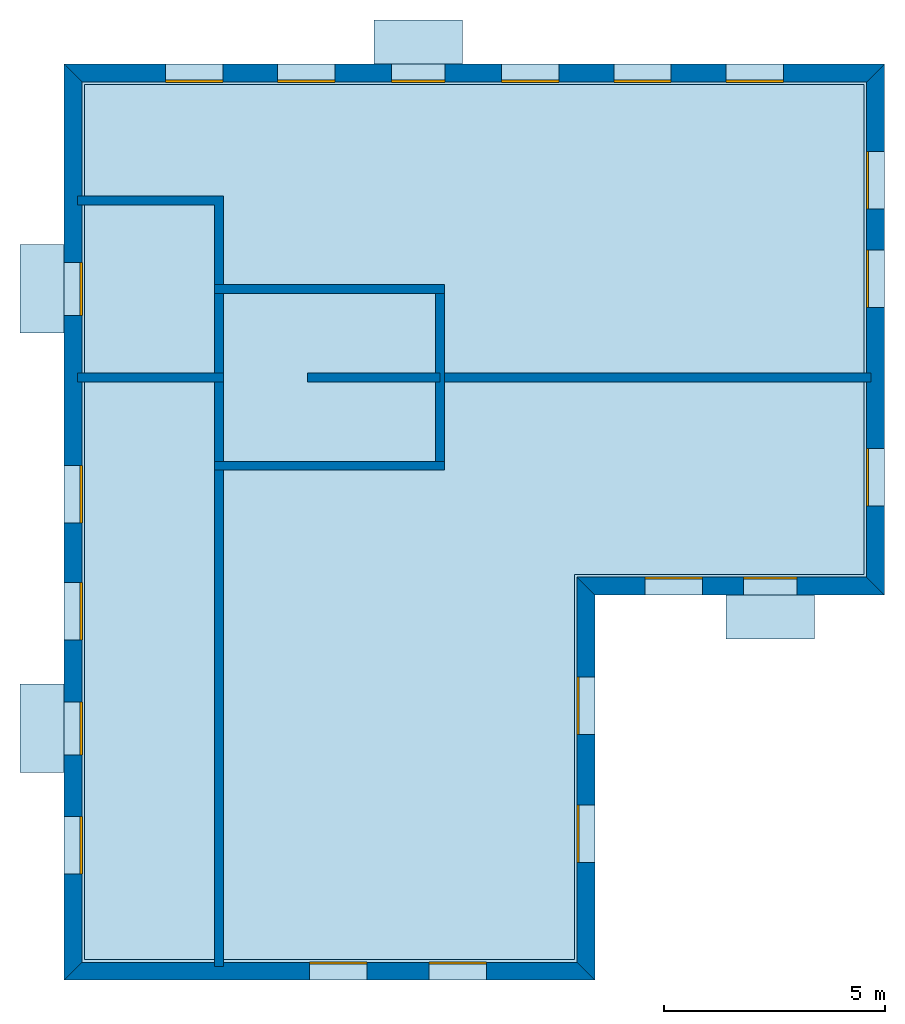
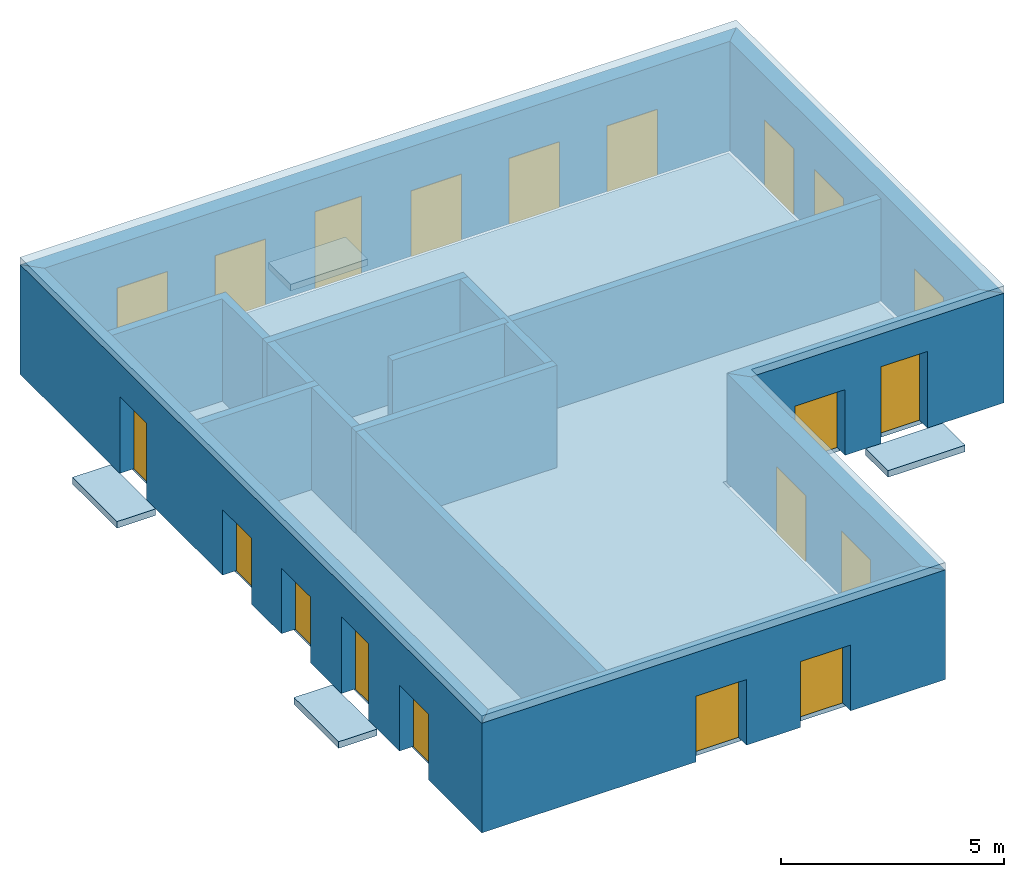
# One storey: 20 windows, 15 walls, 6 slabs, 20 openings.
"""IFC4 building model written with IfcOpenShell, lengths in metres."""

from ifc_helpers import new_model, si_unit, frame, origin_with_axes, place, context, subcontext, project, spatial, polyline, line, indexed_curve, outline, extrude, element, fill, save


model = new_model("IFC4")

# Units and contexts
model_context = context("Model", 3, precision=1e-05, world=origin_with_axes())
body_context = subcontext(model_context, "Body", "Model", "MODEL_VIEW")
ifc_project = project(units=[si_unit("AREAUNIT", "SQUARE_METRE"), si_unit("VOLUMEUNIT", "CUBIC_METRE"), si_unit("LENGTHUNIT", "METRE")], contexts=[model_context])

# Site, building, storey
site = spatial("IfcSite", under=ifc_project)
building = spatial("IfcBuilding", under=site, Name="Building 1")
storey_placement = place(None, frame((0.0, 0.0, 7.0), z_axis=(0.0, 0.0, 1.0), x_axis=(1.0, 0.0, 0.0)))
storey = spatial("IfcBuildingStorey", under=building, at=storey_placement, Name="03 Storey")

# Slabs
slab_1_placement = place(storey_placement, origin_with_axes())
element("IfcSlab", 1, at=slab_1_placement, inside=storey, Name="Slab", context=body_context, shape_type="SweptSolid", body=[
    extrude(outline(indexed_curve([(15.533354, 14.715575), (22.079464, 14.715575), (22.079464, 25.795575), (4.453354, 25.795575), (4.453354, 6.0082), (15.533354, 6.0082)], segments=[line(1, 2), line(2, 3), line(3, 4), line(4, 5), line(5, 6)])), origin_with_axes(), (0.0, 0.0, -1.0), 0.2),
])
slab_2_placement = place(storey_placement, origin_with_axes())
element("IfcSlab", 2, at=slab_2_placement, inside=storey, Name="Balcony", context=body_context, shape_type="SweptSolid", body=[
    extrude(outline(indexed_curve([(20.9574273333333, 14.255575), (20.9574273333333, 13.255575), (18.9574273333333, 13.255575), (18.9574273333333, 14.255575)], segments=[line(1, 2), line(2, 3), line(3, 4)])), origin_with_axes(), (0.0, 0.0, -1.0), 0.18),
])
slab_3_placement = place(storey_placement, origin_with_axes())
element("IfcSlab", 3, at=slab_3_placement, inside=storey, Name="Balcony", context=body_context, shape_type="SweptSolid", body=[
    extrude(outline(indexed_curve([(10.9988297142857, 26.255575), (10.9988297142857, 27.255575), (12.9988297142857, 27.255575), (12.9988297142857, 26.255575)], segments=[line(1, 2), line(2, 3), line(3, 4)])), origin_with_axes(), (0.0, 0.0, -1.0), 0.18),
])
slab_4_placement = place(storey_placement, origin_with_axes())
element("IfcSlab", 4, at=slab_4_placement, inside=storey, Name="Balcony", context=body_context, shape_type="SweptSolid", body=[
    extrude(outline(indexed_curve([(3.993354, 10.2388972), (2.993354, 10.2388972), (2.993354, 12.2388972), (3.993354, 12.2388972)], segments=[line(1, 2), line(2, 3), line(3, 4)])), origin_with_axes(), (0.0, 0.0, -1.0), 0.18),
])
slab_5_placement = place(storey_placement, origin_with_axes())
element("IfcSlab", 5, at=slab_5_placement, inside=storey, Name="Balcony", context=body_context, shape_type="SweptSolid", body=[
    extrude(outline(indexed_curve([(3.993354, 20.174943), (2.993354, 20.174943), (2.993354, 22.174943), (3.993354, 22.174943)], segments=[line(1, 2), line(2, 3), line(3, 4)])), origin_with_axes(), (0.0, 0.0, -1.0), 0.18),
])
slab_6_placement = place(storey_placement, frame((15.993353843689, 14.2555751800537, 0.0), z_axis=(0.0, 0.0, 1.0), x_axis=(1.0, 0.0, 0.0)))
element("IfcSlab", 6, at=slab_6_placement, inside=storey, Name="Slab", context=body_context, shape_type="SweptSolid", body=[
    extrude(outline(polyline([(0.0, 0.0), (6.54611, 0.0), (6.54611, 12.0), (-12.0, 12.0), (-12.0, -8.707375), (0.0, -8.707375), (0.0, 0.0)])), frame((0.0, 0.0, 3.0), z_axis=(0.0, 0.0, 1.0), x_axis=(1.0, 0.0, 0.0)), (0.0, 7.54979012640433e-08, 1.0), 0.2),
])

# Walls
wall_1_placement = place(storey_placement, origin_with_axes())
element("IfcWall", 7, at=wall_1_placement, inside=storey, Name="Wall", context=body_context, shape_type="SweptSolid", body=[
    extrude(outline(indexed_curve([(22.239464, 19.274943), (12.393354, 19.274943), (12.393354, 19.074943), (22.239464, 19.074943)], segments=[line(1, 2), line(2, 3), line(3, 4)])), origin_with_axes(), (0.0, 0.0, 1.0), 2.8),
])
wall_2_placement = place(storey_placement, origin_with_axes())
element("IfcWall", 8, at=wall_2_placement, inside=storey, Name="Wall", context=body_context, shape_type="SweptSolid", body=[
    extrude(outline(indexed_curve([(7.593354, 17.274943), (7.393354, 17.274943), (7.393354, 5.8482), (7.593354, 5.8482)], segments=[line(1, 2), line(2, 3), line(3, 4)])), origin_with_axes(), (0.0, 0.0, 1.0), 2.8),
])
wall_3_placement = place(storey_placement, origin_with_axes())
element("IfcWall", 9, at=wall_3_placement, inside=storey, Name="Wall", context=body_context, shape_type="SweptSolid", body=[
    extrude(outline(indexed_curve([(7.593354, 19.274943), (4.293354, 19.274943), (4.293354, 19.074943), (7.593354, 19.074943)], segments=[line(1, 2), line(2, 3), line(3, 4)])), origin_with_axes(), (0.0, 0.0, 1.0), 2.8),
])
wall_4_placement = place(storey_placement, origin_with_axes())
element("IfcWall", 10, at=wall_4_placement, inside=storey, Name="Wall", context=body_context, shape_type="SweptSolid", body=[
    extrude(outline(indexed_curve([(7.593354, 23.274943), (4.293354, 23.274943), (4.293354, 23.074943), (7.393354, 23.074943), (7.393354, 21.074943), (7.593354, 21.074943)], segments=[line(1, 2), line(2, 3), line(3, 4), line(4, 5), line(5, 6)])), origin_with_axes(), (0.0, 0.0, 1.0), 2.8),
])

# Wall, openings, windows
wall_5_placement = place(storey_placement, origin_with_axes())
wall_5 = element("IfcWall", 11, at=wall_5_placement, inside=storey, Name="Facade", context=body_context, shape_type="SweptSolid", body=[
    extrude(outline(indexed_curve([(15.593354, 14.655575), (22.139464, 14.655575), (22.539464, 14.255575), (15.993354, 14.255575)], segments=[line(1, 2), line(2, 3), line(3, 4)])), origin_with_axes(), (0.0, 0.0, 1.0), 3.0),
])
opening_1_placement = place(wall_5_placement, origin_with_axes())
opening_1 = element("IfcOpeningElement", 12, at=opening_1_placement, cuts=wall_5, Name="Opening", context=body_context, shape_type="SweptSolid", body=[
    extrude(outline(indexed_curve([(17.1253906666667, 14.215575), (17.1253906666667, 14.715575), (18.4253906666667, 14.715575), (18.4253906666667, 14.215575)], segments=[line(1, 2), line(2, 3), line(3, 4)])), origin_with_axes(), (0.0, 0.0, 1.0), 1.8),
])
opening_2_placement = place(wall_5_placement, origin_with_axes())
opening_2 = element("IfcOpeningElement", 13, at=opening_2_placement, cuts=wall_5, Name="Opening", context=body_context, shape_type="SweptSolid", body=[
    extrude(outline(indexed_curve([(19.3574273333333, 14.215575), (19.3574273333333, 14.715575), (20.5574273333333, 14.715575), (20.5574273333333, 14.215575)], segments=[line(1, 2), line(2, 3), line(3, 4)])), origin_with_axes(), (0.0, 0.0, 1.0), 2.1),
])
window_1_placement = place(storey_placement, origin_with_axes())
window_1 = element("IfcWindow", 14, at=window_1_placement, inside=storey, Name="Window", PredefinedType="WINDOW", context=body_context, shape_type="SweptSolid", body=[
    extrude(outline(indexed_curve([(17.1253906666667, 14.615575), (17.1253906666667, 14.665575), (18.4253906666667, 14.665575), (18.4253906666667, 14.615575)], segments=[line(1, 2), line(2, 3), line(3, 4)])), origin_with_axes(), (0.0, 0.0, 1.0), 1.8),
])
fill(opening_1, window_1)
window_2_placement = place(storey_placement, origin_with_axes())
window_2 = element("IfcWindow", 15, at=window_2_placement, inside=storey, Name="Window", PredefinedType="WINDOW", context=body_context, shape_type="SweptSolid", body=[
    extrude(outline(indexed_curve([(19.3574273333333, 14.615575), (19.3574273333333, 14.665575), (20.5574273333333, 14.665575), (20.5574273333333, 14.615575)], segments=[line(1, 2), line(2, 3), line(3, 4)])), origin_with_axes(), (0.0, 0.0, 1.0), 2.1),
])
fill(opening_2, window_2)

wall_6_placement = place(storey_placement, origin_with_axes())
wall_6 = element("IfcWall", 16, at=wall_6_placement, inside=storey, Name="Facade", context=body_context, shape_type="SweptSolid", body=[
    extrude(outline(indexed_curve([(22.139464, 14.655575), (22.139464, 25.855575), (22.539464, 26.255575), (22.539464, 14.255575)], segments=[line(1, 2), line(2, 3), line(3, 4)])), origin_with_axes(), (0.0, 0.0, 1.0), 3.0),
])
opening_3_placement = place(wall_6_placement, origin_with_axes())
opening_3 = element("IfcOpeningElement", 17, at=opening_3_placement, cuts=wall_6, Name="Opening", context=body_context, shape_type="SweptSolid", body=[
    extrude(outline(indexed_curve([(22.579464, 16.265259), (22.079464, 16.265259), (22.079464, 17.565259), (22.579464, 17.565259)], segments=[line(1, 2), line(2, 3), line(3, 4)])), origin_with_axes(), (0.0, 0.0, 1.0), 1.8),
])
opening_4_placement = place(wall_6_placement, origin_with_axes())
opening_4 = element("IfcOpeningElement", 18, at=opening_4_placement, cuts=wall_6, Name="Opening", context=body_context, shape_type="SweptSolid", body=[
    extrude(outline(indexed_curve([(22.579464, 20.7518203333333), (22.079464, 20.7518203333333), (22.079464, 22.0518203333333), (22.579464, 22.0518203333333)], segments=[line(1, 2), line(2, 3), line(3, 4)])), origin_with_axes(), (0.0, 0.0, 1.0), 1.8),
])
opening_5_placement = place(wall_6_placement, origin_with_axes())
opening_5 = element("IfcOpeningElement", 19, at=opening_5_placement, cuts=wall_6, Name="Opening", context=body_context, shape_type="SweptSolid", body=[
    extrude(outline(indexed_curve([(22.579464, 22.9786976666667), (22.079464, 22.9786976666667), (22.079464, 24.2786976666667), (22.579464, 24.2786976666667)], segments=[line(1, 2), line(2, 3), line(3, 4)])), origin_with_axes(), (0.0, 0.0, 1.0), 1.8),
])
window_3_placement = place(storey_placement, origin_with_axes())
window_3 = element("IfcWindow", 20, at=window_3_placement, inside=storey, Name="Window", PredefinedType="WINDOW", context=body_context, shape_type="SweptSolid", body=[
    extrude(outline(indexed_curve([(22.179464, 16.265259), (22.129464, 16.265259), (22.129464, 17.565259), (22.179464, 17.565259)], segments=[line(1, 2), line(2, 3), line(3, 4)])), origin_with_axes(), (0.0, 0.0, 1.0), 1.8),
])
fill(opening_3, window_3)
window_4_placement = place(storey_placement, origin_with_axes())
window_4 = element("IfcWindow", 21, at=window_4_placement, inside=storey, Name="Window", PredefinedType="WINDOW", context=body_context, shape_type="SweptSolid", body=[
    extrude(outline(indexed_curve([(22.179464, 20.7518203333333), (22.129464, 20.7518203333333), (22.129464, 22.0518203333333), (22.179464, 22.0518203333333)], segments=[line(1, 2), line(2, 3), line(3, 4)])), origin_with_axes(), (0.0, 0.0, 1.0), 1.8),
])
fill(opening_4, window_4)
window_5_placement = place(storey_placement, origin_with_axes())
window_5 = element("IfcWindow", 22, at=window_5_placement, inside=storey, Name="Window", PredefinedType="WINDOW", context=body_context, shape_type="SweptSolid", body=[
    extrude(outline(indexed_curve([(22.179464, 22.9786976666667), (22.129464, 22.9786976666667), (22.129464, 24.2786976666667), (22.179464, 24.2786976666667)], segments=[line(1, 2), line(2, 3), line(3, 4)])), origin_with_axes(), (0.0, 0.0, 1.0), 1.8),
])
fill(opening_5, window_5)

wall_7_placement = place(storey_placement, origin_with_axes())
wall_7 = element("IfcWall", 23, at=wall_7_placement, inside=storey, Name="Facade", context=body_context, shape_type="SweptSolid", body=[
    extrude(outline(indexed_curve([(22.139464, 25.855575), (4.393354, 25.855575), (3.993354, 26.255575), (22.539464, 26.255575)], segments=[line(1, 2), line(2, 3), line(3, 4)])), origin_with_axes(), (0.0, 0.0, 1.0), 3.0),
])
opening_6_placement = place(wall_7_placement, origin_with_axes())
opening_6 = element("IfcOpeningElement", 24, at=opening_6_placement, cuts=wall_7, Name="Opening", context=body_context, shape_type="SweptSolid", body=[
    extrude(outline(indexed_curve([(20.2543054285714, 26.295575), (20.2543054285714, 25.795575), (18.9543054285714, 25.795575), (18.9543054285714, 26.295575)], segments=[line(1, 2), line(2, 3), line(3, 4)])), origin_with_axes(), (0.0, 0.0, 1.0), 1.8),
])
opening_7_placement = place(wall_7_placement, origin_with_axes())
opening_7 = element("IfcOpeningElement", 25, at=opening_7_placement, cuts=wall_7, Name="Opening", context=body_context, shape_type="SweptSolid", body=[
    extrude(outline(indexed_curve([(17.7191468571429, 26.295575), (17.7191468571429, 25.795575), (16.4191468571429, 25.795575), (16.4191468571429, 26.295575)], segments=[line(1, 2), line(2, 3), line(3, 4)])), origin_with_axes(), (0.0, 0.0, 1.0), 1.8),
])
opening_8_placement = place(wall_7_placement, origin_with_axes())
opening_8 = element("IfcOpeningElement", 26, at=opening_8_placement, cuts=wall_7, Name="Opening", context=body_context, shape_type="SweptSolid", body=[
    extrude(outline(indexed_curve([(15.1839882857143, 26.295575), (15.1839882857143, 25.795575), (13.8839882857143, 25.795575), (13.8839882857143, 26.295575)], segments=[line(1, 2), line(2, 3), line(3, 4)])), origin_with_axes(), (0.0, 0.0, 1.0), 1.8),
])
opening_9_placement = place(wall_7_placement, origin_with_axes())
opening_9 = element("IfcOpeningElement", 27, at=opening_9_placement, cuts=wall_7, Name="Opening", context=body_context, shape_type="SweptSolid", body=[
    extrude(outline(indexed_curve([(12.5988297142857, 26.295575), (12.5988297142857, 25.795575), (11.3988297142857, 25.795575), (11.3988297142857, 26.295575)], segments=[line(1, 2), line(2, 3), line(3, 4)])), origin_with_axes(), (0.0, 0.0, 1.0), 2.1),
])
opening_10_placement = place(wall_7_placement, origin_with_axes())
opening_10 = element("IfcOpeningElement", 28, at=opening_10_placement, cuts=wall_7, Name="Opening", context=body_context, shape_type="SweptSolid", body=[
    extrude(outline(indexed_curve([(10.1136711428571, 26.295575), (10.1136711428571, 25.795575), (8.81367114285714, 25.795575), (8.81367114285714, 26.295575)], segments=[line(1, 2), line(2, 3), line(3, 4)])), origin_with_axes(), (0.0, 0.0, 1.0), 1.8),
])
opening_11_placement = place(wall_7_placement, origin_with_axes())
opening_11 = element("IfcOpeningElement", 29, at=opening_11_placement, cuts=wall_7, Name="Opening", context=body_context, shape_type="SweptSolid", body=[
    extrude(outline(indexed_curve([(7.57851257142857, 26.295575), (7.57851257142857, 25.795575), (6.27851257142857, 25.795575), (6.27851257142857, 26.295575)], segments=[line(1, 2), line(2, 3), line(3, 4)])), origin_with_axes(), (0.0, 0.0, 1.0), 1.8),
])
window_6_placement = place(storey_placement, origin_with_axes())
window_6 = element("IfcWindow", 30, at=window_6_placement, inside=storey, Name="Window", PredefinedType="WINDOW", context=body_context, shape_type="SweptSolid", body=[
    extrude(outline(indexed_curve([(20.2543054285714, 25.895575), (20.2543054285714, 25.845575), (18.9543054285714, 25.845575), (18.9543054285714, 25.895575)], segments=[line(1, 2), line(2, 3), line(3, 4)])), origin_with_axes(), (0.0, 0.0, 1.0), 1.8),
])
fill(opening_6, window_6)
window_7_placement = place(storey_placement, origin_with_axes())
window_7 = element("IfcWindow", 31, at=window_7_placement, inside=storey, Name="Window", PredefinedType="WINDOW", context=body_context, shape_type="SweptSolid", body=[
    extrude(outline(indexed_curve([(17.7191468571429, 25.895575), (17.7191468571429, 25.845575), (16.4191468571429, 25.845575), (16.4191468571429, 25.895575)], segments=[line(1, 2), line(2, 3), line(3, 4)])), origin_with_axes(), (0.0, 0.0, 1.0), 1.8),
])
fill(opening_7, window_7)
window_8_placement = place(storey_placement, origin_with_axes())
window_8 = element("IfcWindow", 32, at=window_8_placement, inside=storey, Name="Window", PredefinedType="WINDOW", context=body_context, shape_type="SweptSolid", body=[
    extrude(outline(indexed_curve([(15.1839882857143, 25.895575), (15.1839882857143, 25.845575), (13.8839882857143, 25.845575), (13.8839882857143, 25.895575)], segments=[line(1, 2), line(2, 3), line(3, 4)])), origin_with_axes(), (0.0, 0.0, 1.0), 1.8),
])
fill(opening_8, window_8)
window_9_placement = place(storey_placement, origin_with_axes())
window_9 = element("IfcWindow", 33, at=window_9_placement, inside=storey, Name="Window", PredefinedType="WINDOW", context=body_context, shape_type="SweptSolid", body=[
    extrude(outline(indexed_curve([(12.5988297142857, 25.895575), (12.5988297142857, 25.845575), (11.3988297142857, 25.845575), (11.3988297142857, 25.895575)], segments=[line(1, 2), line(2, 3), line(3, 4)])), origin_with_axes(), (0.0, 0.0, 1.0), 2.1),
])
fill(opening_9, window_9)
window_10_placement = place(storey_placement, origin_with_axes())
window_10 = element("IfcWindow", 34, at=window_10_placement, inside=storey, Name="Window", PredefinedType="WINDOW", context=body_context, shape_type="SweptSolid", body=[
    extrude(outline(indexed_curve([(10.1136711428571, 25.895575), (10.1136711428571, 25.845575), (8.81367114285714, 25.845575), (8.81367114285714, 25.895575)], segments=[line(1, 2), line(2, 3), line(3, 4)])), origin_with_axes(), (0.0, 0.0, 1.0), 1.8),
])
fill(opening_10, window_10)
window_11_placement = place(storey_placement, origin_with_axes())
window_11 = element("IfcWindow", 35, at=window_11_placement, inside=storey, Name="Window", PredefinedType="WINDOW", context=body_context, shape_type="SweptSolid", body=[
    extrude(outline(indexed_curve([(7.57851257142857, 25.895575), (7.57851257142857, 25.845575), (6.27851257142857, 25.845575), (6.27851257142857, 25.895575)], segments=[line(1, 2), line(2, 3), line(3, 4)])), origin_with_axes(), (0.0, 0.0, 1.0), 1.8),
])
fill(opening_11, window_11)

wall_8_placement = place(storey_placement, origin_with_axes())
wall_8 = element("IfcWall", 36, at=wall_8_placement, inside=storey, Name="Facade", context=body_context, shape_type="SweptSolid", body=[
    extrude(outline(indexed_curve([(4.393354, 25.855575), (4.393354, 5.9482), (3.993354, 5.5482), (3.993354, 26.255575)], segments=[line(1, 2), line(2, 3), line(3, 4)])), origin_with_axes(), (0.0, 0.0, 1.0), 3.0),
])
opening_12_placement = place(wall_8_placement, origin_with_axes())
opening_12 = element("IfcOpeningElement", 37, at=opening_12_placement, cuts=wall_8, Name="Opening", context=body_context, shape_type="SweptSolid", body=[
    extrude(outline(indexed_curve([(3.953354, 17.1795944), (4.453354, 17.1795944), (4.453354, 15.8795944), (3.953354, 15.8795944)], segments=[line(1, 2), line(2, 3), line(3, 4)])), origin_with_axes(), (0.0, 0.0, 1.0), 1.8),
])
opening_13_placement = place(wall_8_placement, origin_with_axes())
opening_13 = element("IfcOpeningElement", 38, at=opening_13_placement, cuts=wall_8, Name="Opening", context=body_context, shape_type="SweptSolid", body=[
    extrude(outline(indexed_curve([(3.953354, 14.5342458), (4.453354, 14.5342458), (4.453354, 13.2342458), (3.953354, 13.2342458)], segments=[line(1, 2), line(2, 3), line(3, 4)])), origin_with_axes(), (0.0, 0.0, 1.0), 1.8),
])
opening_14_placement = place(wall_8_placement, origin_with_axes())
opening_14 = element("IfcOpeningElement", 39, at=opening_14_placement, cuts=wall_8, Name="Opening", context=body_context, shape_type="SweptSolid", body=[
    extrude(outline(indexed_curve([(3.953354, 11.8388972), (4.453354, 11.8388972), (4.453354, 10.6388972), (3.953354, 10.6388972)], segments=[line(1, 2), line(2, 3), line(3, 4)])), origin_with_axes(), (0.0, 0.0, 1.0), 2.1),
])
opening_15_placement = place(wall_8_placement, origin_with_axes())
opening_15 = element("IfcOpeningElement", 40, at=opening_15_placement, cuts=wall_8, Name="Opening", context=body_context, shape_type="SweptSolid", body=[
    extrude(outline(indexed_curve([(3.953354, 9.2435486), (4.453354, 9.2435486), (4.453354, 7.9435486), (3.953354, 7.9435486)], segments=[line(1, 2), line(2, 3), line(3, 4)])), origin_with_axes(), (0.0, 0.0, 1.0), 1.8),
])
opening_16_placement = place(wall_8_placement, origin_with_axes())
opening_16 = element("IfcOpeningElement", 41, at=opening_16_placement, cuts=wall_8, Name="Opening", context=body_context, shape_type="SweptSolid", body=[
    extrude(outline(indexed_curve([(3.953354, 21.774943), (4.453354, 21.774943), (4.453354, 20.574943), (3.953354, 20.574943)], segments=[line(1, 2), line(2, 3), line(3, 4)])), origin_with_axes(), (0.0, 0.0, 1.0), 2.1),
])
window_12_placement = place(storey_placement, origin_with_axes())
window_12 = element("IfcWindow", 42, at=window_12_placement, inside=storey, Name="Window", PredefinedType="WINDOW", context=body_context, shape_type="SweptSolid", body=[
    extrude(outline(indexed_curve([(4.353354, 17.1795944), (4.403354, 17.1795944), (4.403354, 15.8795944), (4.353354, 15.8795944)], segments=[line(1, 2), line(2, 3), line(3, 4)])), origin_with_axes(), (0.0, 0.0, 1.0), 1.8),
])
fill(opening_12, window_12)
window_13_placement = place(storey_placement, origin_with_axes())
window_13 = element("IfcWindow", 43, at=window_13_placement, inside=storey, Name="Window", PredefinedType="WINDOW", context=body_context, shape_type="SweptSolid", body=[
    extrude(outline(indexed_curve([(4.353354, 14.5342458), (4.403354, 14.5342458), (4.403354, 13.2342458), (4.353354, 13.2342458)], segments=[line(1, 2), line(2, 3), line(3, 4)])), origin_with_axes(), (0.0, 0.0, 1.0), 1.8),
])
fill(opening_13, window_13)
window_14_placement = place(storey_placement, origin_with_axes())
window_14 = element("IfcWindow", 44, at=window_14_placement, inside=storey, Name="Window", PredefinedType="WINDOW", context=body_context, shape_type="SweptSolid", body=[
    extrude(outline(indexed_curve([(4.353354, 11.8388972), (4.403354, 11.8388972), (4.403354, 10.6388972), (4.353354, 10.6388972)], segments=[line(1, 2), line(2, 3), line(3, 4)])), origin_with_axes(), (0.0, 0.0, 1.0), 2.1),
])
fill(opening_14, window_14)
window_15_placement = place(storey_placement, origin_with_axes())
window_15 = element("IfcWindow", 45, at=window_15_placement, inside=storey, Name="Window", PredefinedType="WINDOW", context=body_context, shape_type="SweptSolid", body=[
    extrude(outline(indexed_curve([(4.353354, 9.2435486), (4.403354, 9.2435486), (4.403354, 7.9435486), (4.353354, 7.9435486)], segments=[line(1, 2), line(2, 3), line(3, 4)])), origin_with_axes(), (0.0, 0.0, 1.0), 1.8),
])
fill(opening_15, window_15)
window_16_placement = place(storey_placement, origin_with_axes())
window_16 = element("IfcWindow", 46, at=window_16_placement, inside=storey, Name="Window", PredefinedType="WINDOW", context=body_context, shape_type="SweptSolid", body=[
    extrude(outline(indexed_curve([(4.353354, 21.774943), (4.403354, 21.774943), (4.403354, 20.574943), (4.353354, 20.574943)], segments=[line(1, 2), line(2, 3), line(3, 4)])), origin_with_axes(), (0.0, 0.0, 1.0), 2.1),
])
fill(opening_16, window_16)

wall_9_placement = place(storey_placement, origin_with_axes())
wall_9 = element("IfcWall", 47, at=wall_9_placement, inside=storey, Name="Facade", context=body_context, shape_type="SweptSolid", body=[
    extrude(outline(indexed_curve([(4.393354, 5.9482), (15.593354, 5.9482), (15.993354, 5.5482), (3.993354, 5.5482)], segments=[line(1, 2), line(2, 3), line(3, 4)])), origin_with_axes(), (0.0, 0.0, 1.0), 3.0),
])
opening_17_placement = place(wall_9_placement, origin_with_axes())
opening_17 = element("IfcOpeningElement", 48, at=opening_17_placement, cuts=wall_9, Name="Opening", context=body_context, shape_type="SweptSolid", body=[
    extrude(outline(indexed_curve([(9.543354, 5.5082), (9.543354, 6.0082), (10.843354, 6.0082), (10.843354, 5.5082)], segments=[line(1, 2), line(2, 3), line(3, 4)])), origin_with_axes(), (0.0, 0.0, 1.0), 1.8),
])
opening_18_placement = place(wall_9_placement, origin_with_axes())
opening_18 = element("IfcOpeningElement", 49, at=opening_18_placement, cuts=wall_9, Name="Opening", context=body_context, shape_type="SweptSolid", body=[
    extrude(outline(indexed_curve([(12.243354, 5.5082), (12.243354, 6.0082), (13.543354, 6.0082), (13.543354, 5.5082)], segments=[line(1, 2), line(2, 3), line(3, 4)])), origin_with_axes(), (0.0, 0.0, 1.0), 1.8),
])
window_17_placement = place(storey_placement, origin_with_axes())
window_17 = element("IfcWindow", 50, at=window_17_placement, inside=storey, Name="Window", PredefinedType="WINDOW", context=body_context, shape_type="SweptSolid", body=[
    extrude(outline(indexed_curve([(9.543354, 5.9082), (9.543354, 5.9582), (10.843354, 5.9582), (10.843354, 5.9082)], segments=[line(1, 2), line(2, 3), line(3, 4)])), origin_with_axes(), (0.0, 0.0, 1.0), 1.8),
])
fill(opening_17, window_17)
window_18_placement = place(storey_placement, origin_with_axes())
window_18 = element("IfcWindow", 51, at=window_18_placement, inside=storey, Name="Window", PredefinedType="WINDOW", context=body_context, shape_type="SweptSolid", body=[
    extrude(outline(indexed_curve([(12.243354, 5.9082), (12.243354, 5.9582), (13.543354, 5.9582), (13.543354, 5.9082)], segments=[line(1, 2), line(2, 3), line(3, 4)])), origin_with_axes(), (0.0, 0.0, 1.0), 1.8),
])
fill(opening_18, window_18)

wall_10_placement = place(storey_placement, origin_with_axes())
wall_10 = element("IfcWall", 52, at=wall_10_placement, inside=storey, Name="Facade", context=body_context, shape_type="SweptSolid", body=[
    extrude(outline(indexed_curve([(15.593354, 5.9482), (15.593354, 14.655575), (15.993354, 14.255575), (15.993354, 5.5482)], segments=[line(1, 2), line(2, 3), line(3, 4)])), origin_with_axes(), (0.0, 0.0, 1.0), 3.0),
])
opening_19_placement = place(wall_10_placement, origin_with_axes())
opening_19 = element("IfcOpeningElement", 53, at=opening_19_placement, cuts=wall_10, Name="Opening", context=body_context, shape_type="SweptSolid", body=[
    extrude(outline(indexed_curve([(16.033354, 8.20065833333333), (15.533354, 8.20065833333333), (15.533354, 9.50065833333333), (16.033354, 9.50065833333333)], segments=[line(1, 2), line(2, 3), line(3, 4)])), origin_with_axes(), (0.0, 0.0, 1.0), 1.8),
])
opening_20_placement = place(wall_10_placement, origin_with_axes())
opening_20 = element("IfcOpeningElement", 54, at=opening_20_placement, cuts=wall_10, Name="Opening", context=body_context, shape_type="SweptSolid", body=[
    extrude(outline(indexed_curve([(16.033354, 11.1031166666667), (15.533354, 11.1031166666667), (15.533354, 12.4031166666667), (16.033354, 12.4031166666667)], segments=[line(1, 2), line(2, 3), line(3, 4)])), origin_with_axes(), (0.0, 0.0, 1.0), 1.8),
])
window_19_placement = place(storey_placement, origin_with_axes())
window_19 = element("IfcWindow", 55, at=window_19_placement, inside=storey, Name="Window", PredefinedType="WINDOW", context=body_context, shape_type="SweptSolid", body=[
    extrude(outline(indexed_curve([(15.633354, 8.20065833333333), (15.583354, 8.20065833333333), (15.583354, 9.50065833333333), (15.633354, 9.50065833333333)], segments=[line(1, 2), line(2, 3), line(3, 4)])), origin_with_axes(), (0.0, 0.0, 1.0), 1.8),
])
fill(opening_19, window_19)
window_20_placement = place(storey_placement, origin_with_axes())
window_20 = element("IfcWindow", 56, at=window_20_placement, inside=storey, Name="Window", PredefinedType="WINDOW", context=body_context, shape_type="SweptSolid", body=[
    extrude(outline(indexed_curve([(15.633354, 11.1031166666667), (15.583354, 11.1031166666667), (15.583354, 12.4031166666667), (15.633354, 12.4031166666667)], segments=[line(1, 2), line(2, 3), line(3, 4)])), origin_with_axes(), (0.0, 0.0, 1.0), 1.8),
])
fill(opening_20, window_20)

# Walls
wall_11_placement = place(storey_placement, origin_with_axes())
element("IfcWall", 57, at=wall_11_placement, inside=storey, Name="CoreWall", context=body_context, shape_type="SweptSolid", body=[
    extrude(outline(indexed_curve([(12.593354, 21.274943), (7.393354, 21.274943), (7.393354, 21.074943), (12.593354, 21.074943)], segments=[line(1, 2), line(2, 3), line(3, 4)])), origin_with_axes(), (0.0, 0.0, 1.0), 2.8),
])
wall_12_placement = place(storey_placement, origin_with_axes())
element("IfcWall", 58, at=wall_12_placement, inside=storey, Name="CoreWall", context=body_context, shape_type="SweptSolid", body=[
    extrude(outline(indexed_curve([(7.393354, 17.074943), (12.593354, 17.074943), (12.593354, 17.274943), (7.393354, 17.274943)], segments=[line(1, 2), line(2, 3), line(3, 4)])), origin_with_axes(), (0.0, 0.0, 1.0), 2.8),
])
wall_13_placement = place(storey_placement, origin_with_axes())
element("IfcWall", 59, at=wall_13_placement, inside=storey, Name="CoreWall", context=body_context, shape_type="SweptSolid", body=[
    extrude(outline(indexed_curve([(7.593354, 17.274943), (7.593354, 21.074943), (7.393354, 21.074943), (7.393354, 17.274943)], segments=[line(1, 2), line(2, 3), line(3, 4)])), origin_with_axes(), (0.0, 0.0, 1.0), 2.8),
])
wall_14_placement = place(storey_placement, origin_with_axes())
element("IfcWall", 60, at=wall_14_placement, inside=storey, Name="CoreWall", context=body_context, shape_type="SweptSolid", body=[
    extrude(outline(indexed_curve([(12.393354, 21.074943), (12.393354, 17.274943), (12.593354, 17.274943), (12.593354, 21.074943)], segments=[line(1, 2), line(2, 3), line(3, 4)])), origin_with_axes(), (0.0, 0.0, 1.0), 2.8),
])
wall_15_placement = place(storey_placement, origin_with_axes())
element("IfcWall", 61, at=wall_15_placement, inside=storey, Name="CoreWall", context=body_context, shape_type="SweptSolid", body=[
    extrude(outline(indexed_curve([(12.493354, 19.274943), (9.493354, 19.274943), (9.493354, 19.074943), (12.493354, 19.074943)], segments=[line(1, 2), line(2, 3), line(3, 4)])), origin_with_axes(), (0.0, 0.0, 1.0), 2.8),
])

save(model, "model.ifc")
